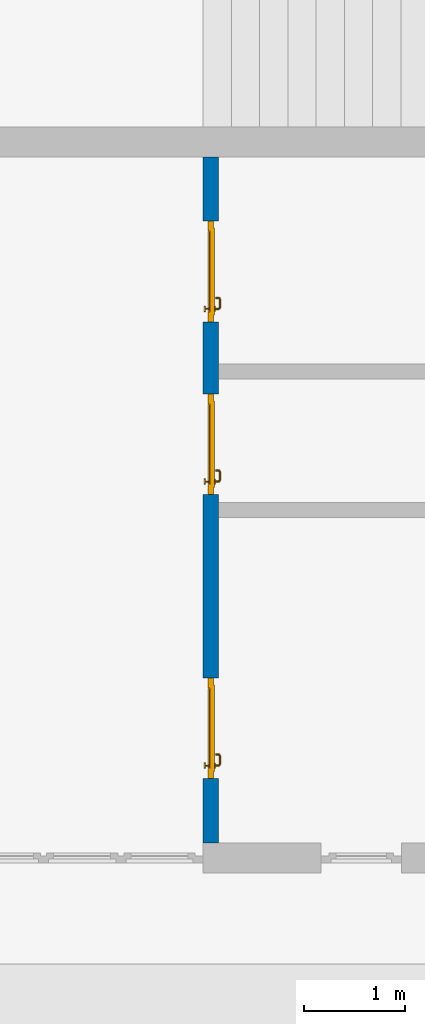
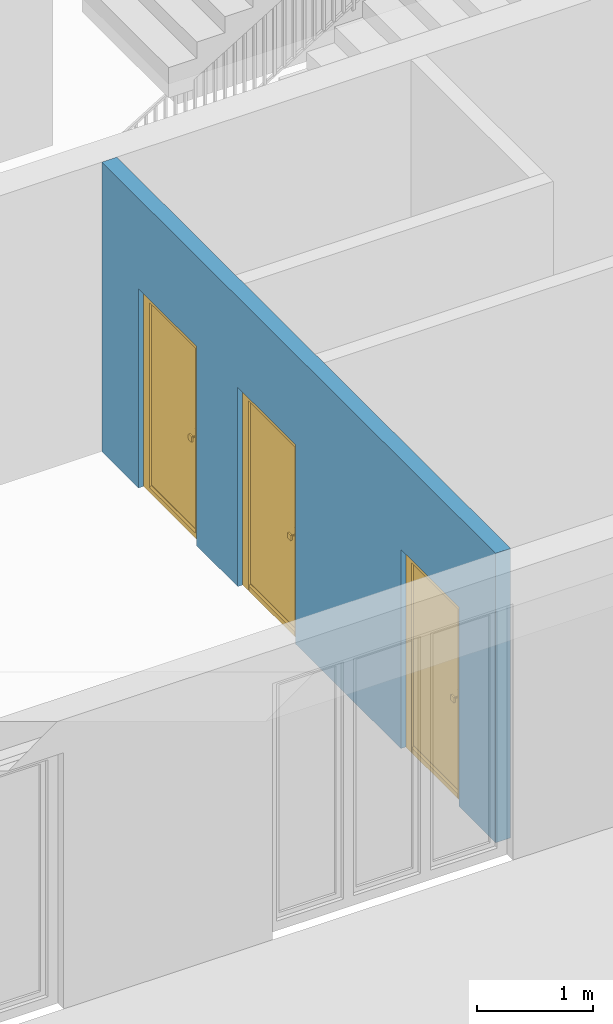
# One storey, part 4 of 23: 3 doors, 1 wall, 3 openings.
"""IFC4 building model written with IfcOpenShell, lengths in metres."""

from ifc_helpers import new_model, entity, si_unit, converted_unit, derived_unit, direction, frame, origin_with_axes, place, context, subcontext, project, spatial, polygons, source, transform, mapped, material, type_object, element, fill, save


model = new_model("IFC4")

# Units and contexts
model_context = context("Model", 3, precision=1e-05, world=origin_with_axes(), true_north=direction((0.0, 1.0)))
body_context = subcontext(model_context, "Body", "Model", "MODEL_VIEW")
ifc_project = project(units=[si_unit("LENGTHUNIT", "METRE"), si_unit("AREAUNIT", "SQUARE_METRE"), si_unit("VOLUMEUNIT", "CUBIC_METRE"), converted_unit("PLANEANGLEUNIT", "DEGREE", entity("IfcPlaneAngleMeasure", 0.0174532925199), si_unit("PLANEANGLEUNIT", "RADIAN"), dimensions=[0, 0, 0, 0, 0, 0, 0]), converted_unit("TIMEUNIT", "Year", entity("IfcTimeMeasure", 31556926.0), si_unit("TIMEUNIT", "SECOND"), dimensions=[0, 0, 1, 0, 0, 0, 0]), si_unit("MASSUNIT", "GRAM", prefix="KILO"), si_unit("THERMODYNAMICTEMPERATUREUNIT", "DEGREE_CELSIUS"), si_unit("LUMINOUSINTENSITYUNIT", "LUMEN"), si_unit("ENERGYUNIT", "JOULE", prefix="MEGA"), derived_unit("THERMALCONDUCTANCEUNIT", [(si_unit("POWERUNIT", "WATT"), 1), (si_unit("LENGTHUNIT", "METRE"), -1), (si_unit("THERMODYNAMICTEMPERATUREUNIT", "KELVIN"), -1)]), derived_unit("SPECIFICHEATCAPACITYUNIT", [(si_unit("ENERGYUNIT", "JOULE"), 1), (si_unit("MASSUNIT", "GRAM", prefix="KILO"), -1), (si_unit("THERMODYNAMICTEMPERATUREUNIT", "KELVIN"), -1)]), derived_unit("MASSDENSITYUNIT", [(si_unit("MASSUNIT", "GRAM", prefix="KILO"), 1), (si_unit("VOLUMEUNIT", "CUBIC_METRE"), -1)])], contexts=[model_context])

# Site, building, storey
site_placement = place(None, origin_with_axes())
site = spatial("IfcSite", under=ifc_project, at=site_placement, CompositionType="ELEMENT")
building_placement = place(site_placement, origin_with_axes())
building = spatial("IfcBuilding", under=site, at=building_placement, CompositionType="ELEMENT")
storey_placement = place(building_placement, origin_with_axes())
storey = spatial("IfcBuildingStorey", under=building, at=storey_placement, Name="0. Geschoss", CompositionType="ELEMENT", Elevation=0.0)

# Wall, openings, doors
ifc_material = material()
wall_type = type_object("IfcWallType", Name="150", PredefinedType="NOTDEFINED")
wall_placement = place(storey_placement, frame((-4.2821993804, -9.92881223104, 0.0), z_axis=(0.0, 0.0, 1.0), x_axis=(0.0, 1.0, 0.0)))
wall = element("IfcWall", 1, at=wall_placement, inside=storey, type_object=wall_type, material=ifc_material, Name="Wand-002", PredefinedType="NOTDEFINED", context=body_context, shape_type="Tessellation", body=[
    polygons([(0.936333441648, -0.15, 0.0), (0.936333441648, -0.15, 2.1), (1.93633344165, -0.15, 2.1), (1.93633344165, -0.15, 0.0), (3.75305810182, -0.15, 0.0), (3.75305810182, -0.15, 2.1), (4.75305810182, -0.15, 2.1), (4.75305810182, -0.15, 0.0), (5.46546310046, -0.15, 0.0), (5.46546310046, -0.15, 2.1), (6.46546310046, -0.15, 2.1), (6.46546310046, -0.15, 0.0), (7.1, -0.15, 0.0), (7.1, -0.15, 3.05), (0.3, -0.15, 3.05), (0.3, -0.15, 0.0), (0.936333441648, -0.05, 0.0), (0.936333441648, 0.0, 0.0), (0.936333441648, 0.0, 2.1), (1.93633344165, 0.0, 2.1), (1.93633344165, -0.05, 0.0), (1.93633344165, 0.0, 0.0), (3.75305810182, 0.0, 0.0), (3.75305810182, 0.0, 2.1), (4.75305810182, 0.0, 2.1), (4.75305810182, 0.0, 0.0), (5.46546310046, 0.0, 0.0), (5.46546310046, 0.0, 2.1), (6.46546310046, 0.0, 2.1), (6.46546310046, 0.0, 0.0), (7.1, 0.0, 0.0), (7.1, 0.0, 3.05), (0.3, 0.0, 3.05), (0.3, 0.0, 0.0)], [[[1, 2, 3, 4, 5, 6, 7, 8, 9, 10, 11, 12, 13, 14, 15, 16]], [[2, 1, 17, 18, 19]], [[3, 2, 19, 20]], [[21, 4, 3, 20, 22]], [[4, 21, 22, 23, 5]], [[23, 24, 6, 5]], [[24, 25, 7, 6]], [[25, 26, 8, 7]], [[27, 9, 8, 26]], [[10, 9, 27, 28]], [[11, 10, 28, 29]], [[12, 11, 29, 30]], [[12, 30, 31, 13]], [[14, 13, 31, 32]], [[14, 32, 33, 15]], [[33, 34, 16, 15]], [[17, 1, 16, 34, 18]], [[23, 22, 20, 19, 18, 34, 33, 32, 31, 30, 29, 28, 27, 26, 25, 24]]], closed=True),
])
opening_1_placement = place(wall_placement, frame((5.96546310046, 0.0, 0.0), z_axis=(0.0, 0.0, 1.0), x_axis=(1.0, 0.0, 0.0)))
opening_1 = element("IfcOpeningElement", 2, at=opening_1_placement, cuts=wall, context=body_context, identifier="Reference", shape_type="Tessellation", body=[
    polygons([(-0.5, -0.05, 0.0), (-0.5, -0.05, 2.1), (-0.5, 0.001, 2.1), (-0.5, 0.001, 0.0), (-0.5, -0.151, 0.0), (-0.5, -0.151, 2.1), (0.5, -0.05, 2.1), (0.5, 0.001, 2.1), (0.5, -0.151, 2.1), (0.5, 0.001, 0.0), (0.5, -0.05, 0.0), (0.5, -0.151, 0.0)], [[[1, 2, 3, 4]], [[2, 1, 5, 6]], [[7, 8, 3, 2, 6, 9]], [[8, 10, 4, 3]], [[1, 4, 10, 11, 12, 5]], [[6, 5, 12, 9]], [[7, 11, 10, 8]], [[11, 7, 9, 12]]], closed=True),
])
opening_2_placement = place(wall_placement, frame((4.25305810182, 0.0, 0.0), z_axis=(0.0, 0.0, 1.0), x_axis=(1.0, 0.0, 0.0)))
opening_2 = element("IfcOpeningElement", 3, at=opening_2_placement, cuts=wall, context=body_context, identifier="Reference", shape_type="Tessellation", body=[
    polygons([(-0.5, -0.05, 0.0), (-0.5, -0.05, 2.1), (-0.5, 0.00100000000001, 2.1), (-0.5, 0.00100000000001, 0.0), (-0.5, -0.151, 0.0), (-0.5, -0.151, 2.1), (0.5, -0.05, 2.1), (0.5, 0.00100000000001, 2.1), (0.5, -0.151, 2.1), (0.5, 0.00100000000001, 0.0), (0.5, -0.05, 0.0), (0.5, -0.151, 0.0)], [[[1, 2, 3, 4]], [[2, 1, 5, 6]], [[7, 8, 3, 2, 6, 9]], [[8, 10, 4, 3]], [[1, 4, 10, 11, 12, 5]], [[6, 5, 12, 9]], [[7, 11, 10, 8]], [[11, 7, 9, 12]]], closed=True),
])
opening_3_placement = place(wall_placement, frame((1.43633344165, 0.0, 0.0), z_axis=(0.0, 0.0, 1.0), x_axis=(1.0, 0.0, 0.0)))
opening_3 = element("IfcOpeningElement", 4, at=opening_3_placement, cuts=wall, context=body_context, identifier="Reference", shape_type="Tessellation", body=[
    polygons([(-0.5, -0.05, 0.0), (-0.5, -0.05, 2.1), (-0.5, 0.00100000000001, 2.1), (-0.5, 0.00100000000001, 0.0), (-0.5, -0.151, 0.0), (-0.5, -0.151, 2.1), (0.5, -0.05, 2.1), (0.5, 0.00100000000001, 2.1), (0.5, -0.151, 2.1), (0.5, 0.00100000000001, 0.0), (0.5, -0.05, 0.0), (0.5, -0.151, 0.0)], [[[1, 2, 3, 4]], [[2, 1, 5, 6]], [[7, 8, 3, 2, 6, 9]], [[8, 10, 4, 3]], [[1, 4, 10, 11, 12, 5]], [[6, 5, 12, 9]], [[7, 11, 10, 8]], [[11, 7, 9, 12]]], closed=True),
])
door_type = type_object("IfcDoorType", Name="Eingang 01 1-Fl 26", OperationType="SINGLE_SWING_LEFT", PredefinedType="DOOR")
shared_shape = source(origin_with_axes(), body_context, "Body", "Tessellation", [
    polygons([(-0.5, -0.05, 0.0), (-0.5, -0.05, 2.1), (-0.5, -0.03, 2.1), (-0.5, -0.03, 0.0), (-0.4, -0.05, 0.0), (-0.4, -0.05, 2.0), (-0.1301, -0.05, 2.0), (-0.0001, -0.05, 2.0), (0.4, -0.05, 2.0), (0.4, -0.05, 0.0), (0.5, -0.05, 0.0), (0.5, -0.05, 2.1), (0.5, -0.03, 2.1), (0.5, -0.03, 0.0), (0.4, -0.03, 0.0), (0.4, -0.03, 2.0), (-0.0001, -0.03, 2.0), (-0.1301, -0.03, 2.0), (-0.4, -0.03, 2.0), (-0.4, -0.03, 0.0)], [[[1, 2, 3, 4]], [[1, 5, 6, 7, 8, 9, 10, 11, 12, 2]], [[2, 12, 13, 3]], [[4, 3, 13, 14, 15, 16, 17, 18, 19, 20]], [[5, 1, 4, 20]], [[6, 5, 20, 19]], [[7, 6, 19, 18]], [[8, 7, 18, 17]], [[9, 8, 17, 16]], [[10, 9, 16, 15]], [[11, 10, 15, 14]], [[12, 11, 14, 13]]], closed=True),
    polygons([(-0.5, -0.03, 0.0), (-0.5, -0.03, 2.1), (-0.5, 0.0, 2.1), (-0.5, 0.0, 0.0), (-0.43, -0.03, 0.0), (-0.43, -0.03, 2.03), (-0.1001, -0.03, 2.03), (-0.0301, -0.03, 2.03), (0.43, -0.03, 2.03), (0.43, -0.03, 0.0), (0.5, -0.03, 0.0), (0.5, -0.03, 2.1), (0.5, 0.0, 2.1), (0.5, 0.0, 0.0), (0.43, 0.0, 0.0), (0.43, 0.0, 2.03), (-0.0301, 0.0, 2.03), (-0.1001, 0.0, 2.03), (-0.43, 0.0, 2.03), (-0.43, 0.0, 0.0)], [[[1, 2, 3, 4]], [[1, 5, 6, 7, 8, 9, 10, 11, 12, 2]], [[2, 12, 13, 3]], [[4, 3, 13, 14, 15, 16, 17, 18, 19, 20]], [[5, 1, 4, 20]], [[6, 5, 20, 19]], [[7, 6, 19, 18]], [[8, 7, 18, 17]], [[9, 8, 17, 16]], [[10, 9, 16, 15]], [[11, 10, 15, 14]], [[12, 11, 14, 13]]], closed=True),
    polygons([(-0.43, 0.01, 0.0), (-0.43, 0.01, 2.03), (0.43, 0.01, 2.03), (0.43, 0.01, 0.0), (-0.43, -0.03, 0.0), (-0.43, -0.03, 2.03), (0.43, -0.03, 2.03), (0.43, -0.03, 0.0)], [[[1, 2, 3, 4]], [[1, 5, 6, 2]], [[2, 6, 7, 3]], [[3, 7, 8, 4]], [[4, 8, 5, 1]], [[8, 7, 6, 5]]], closed=True),
    polygons([(-0.395, -0.05, 0.0), (0.395, -0.05, 0.0), (0.395, -0.05, 0.05), (-0.395, -0.05, 0.05), (-0.395, -0.03, 0.0), (0.395, -0.03, 0.0), (0.395, -0.03, 0.07), (0.395, -0.035, 0.07), (-0.395, -0.035, 0.07), (-0.395, -0.03, 0.07)], [[[1, 2, 3, 4]], [[5, 6, 2, 1]], [[2, 6, 7, 8, 3]], [[4, 3, 8, 9]], [[1, 4, 9, 10, 5]], [[10, 7, 6, 5]], [[9, 8, 7, 10]]], closed=True),
    polygons([(0.3835, 0.02, 1.0733826859), (0.37, 0.02, 1.077), (0.37, 0.0199, 1.077), (0.3835, 0.0199, 1.0733826859), (0.393382685902, 0.02, 1.0635), (0.397, 0.02, 1.05), (0.393382685902, 0.02, 1.0365), (0.3835, 0.02, 1.0266173141), (0.37, 0.02, 1.023), (0.3565, 0.02, 1.0266173141), (0.346617314098, 0.02, 1.0365), (0.343, 0.02, 1.05), (0.346617314098, 0.02, 1.0635), (0.3565, 0.02, 1.0733826859), (0.3565, 0.0199, 1.0733826859), (0.37, 0.0101, 1.077), (0.3835, 0.0101, 1.0733826859), (0.393382685902, 0.0199, 1.0635), (0.397, 0.0199, 1.05), (0.393382685902, 0.0199, 1.0365), (0.3835, 0.0199, 1.0266173141), (0.37, 0.0199, 1.023), (0.3565, 0.0199, 1.0266173141), (0.346617314098, 0.0199, 1.0365), (0.343, 0.0199, 1.05), (0.346617314098, 0.0199, 1.0635), (0.3565, 0.0101, 1.0733826859), (0.37, 0.01, 1.077), (0.3835, 0.01, 1.0733826859), (0.393382685902, 0.0101, 1.0635), (0.397, 0.0101, 1.05), (0.393382685902, 0.0101, 1.0365), (0.3835, 0.0101, 1.0266173141), (0.37, 0.0101, 1.023), (0.3565, 0.0101, 1.0266173141), (0.346617314098, 0.0101, 1.0365), (0.343, 0.0101, 1.05), (0.346617314098, 0.0101, 1.0635), (0.3565, 0.01, 1.0733826859), (0.346617314098, 0.01, 1.0635), (0.343, 0.01, 1.05), (0.346617314098, 0.01, 1.0365), (0.3565, 0.01, 1.0266173141), (0.37, 0.01, 1.023), (0.3835, 0.01, 1.0266173141), (0.393382685902, 0.01, 1.0365), (0.397, 0.01, 1.05), (0.393382685902, 0.01, 1.0635)], [[[1, 2, 3, 4]], [[2, 1, 5, 6, 7, 8, 9, 10, 11, 12, 13, 14]], [[2, 14, 15, 3]], [[4, 3, 16, 17]], [[5, 1, 4, 18]], [[6, 5, 18, 19]], [[7, 6, 19, 20]], [[8, 7, 20, 21]], [[9, 8, 21, 22]], [[10, 9, 22, 23]], [[11, 10, 23, 24]], [[12, 11, 24, 25]], [[13, 12, 25, 26]], [[14, 13, 26, 15]], [[3, 15, 27, 16]], [[17, 16, 28, 29]], [[18, 4, 17, 30]], [[19, 18, 30, 31]], [[20, 19, 31, 32]], [[21, 20, 32, 33]], [[22, 21, 33, 34]], [[23, 22, 34, 35]], [[24, 23, 35, 36]], [[25, 24, 36, 37]], [[26, 25, 37, 38]], [[15, 26, 38, 27]], [[16, 27, 39, 28]], [[28, 39, 40, 41, 42, 43, 44, 45, 46, 47, 48, 29]], [[30, 17, 29, 48]], [[31, 30, 48, 47]], [[32, 31, 47, 46]], [[33, 32, 46, 45]], [[34, 33, 45, 44]], [[35, 34, 44, 43]], [[36, 35, 43, 42]], [[37, 36, 42, 41]], [[38, 37, 41, 40]], [[27, 38, 40, 39]]], closed=True),
    polygons([(0.362532169224, 0.019, 0.959692280177), (0.363279754556, 0.019, 0.961639806549), (0.35705, 0.019, 0.972430057958), (0.347569942042, 0.019, 0.96295), (0.365, 0.019, 0.952886751346), (0.365, 0.019, 0.9544), (0.362532169224, 0.02, 0.959692280177), (0.363279754556, 0.02, 0.961639806549), (0.364624817685, 0.02, 0.965143815798), (0.364624817685, 0.019, 0.965143815798), (0.37, 0.019, 0.967425445323), (0.37, 0.019, 0.9759), (0.357, 0.019, 0.972516660498), (0.347483339502, 0.019, 0.963), (0.365, 0.019, 0.95), (0.3441, 0.019, 0.95), (0.365, 0.019, 0.947113248654), (0.365, 0.019, 0.941339745962), (0.365, 0.019, 0.9375), (0.365, 0.02, 0.9375), (0.365, 0.02, 0.941339745962), (0.365, 0.02, 0.947113248654), (0.365, 0.02, 0.95), (0.365, 0.02, 0.952886751346), (0.365, 0.02, 0.9544), (0.346703916638, 0.02, 0.96345), (0.35655, 0.02, 0.973296083362), (0.37, 0.02, 0.9769), (0.37, 0.02, 0.967425445323), (0.375375182315, 0.019, 0.965143815798), (0.376720245444, 0.019, 0.961639806549), (0.38295, 0.019, 0.972430057958), (0.37, 0.019, 0.976), (0.357, 0.0189, 0.972516660498), (0.347483339502, 0.0189, 0.963), (0.344, 0.019, 0.95), (0.347569942042, 0.019, 0.93705), (0.35705, 0.019, 0.927569942042), (0.37, 0.019, 0.9241), (0.37, 0.019, 0.9325), (0.366464466094, 0.019, 0.933964466094), (0.366464466094, 0.02, 0.933964466094), (0.37, 0.02, 0.9231), (0.35655, 0.02, 0.926703916638), (0.37, 0.02, 0.9325), (0.346703916638, 0.02, 0.93655), (0.3431, 0.02, 0.95), (0.346617314098, 0.02, 0.9635), (0.3565, 0.02, 0.973382685902), (0.37, 0.02, 0.977), (0.375375182315, 0.02, 0.965143815798), (0.38345, 0.02, 0.973296083362), (0.376720245444, 0.02, 0.961639806549), (0.377467830776, 0.02, 0.959692280177), (0.377467830776, 0.019, 0.959692280177), (0.375, 0.019, 0.9544), (0.375, 0.019, 0.952886751346), (0.392430057958, 0.019, 0.96295), (0.383, 0.019, 0.972516660498), (0.37, 0.0189, 0.976), (0.357, 0.0101, 0.972516660498), (0.347483339502, 0.0101, 0.963), (0.344, 0.0189, 0.95), (0.347483339502, 0.019, 0.937), (0.357, 0.019, 0.927483339502), (0.37, 0.019, 0.924), (0.38295, 0.019, 0.927569942042), (0.375, 0.019, 0.941339745962), (0.375, 0.019, 0.9375), (0.373535533906, 0.019, 0.933964466094), (0.37, 0.02, 0.923), (0.3565, 0.02, 0.926617314098), (0.38345, 0.02, 0.926703916638), (0.373535533906, 0.02, 0.933964466094), (0.375, 0.02, 0.9375), (0.375, 0.02, 0.941339745962), (0.346617314098, 0.02, 0.9365), (0.343, 0.02, 0.95), (0.346617314098, 0.0199, 0.9635), (0.3565, 0.0199, 0.973382685902), (0.37, 0.0199, 0.977), (0.3835, 0.02, 0.973382685902), (0.393296083362, 0.02, 0.96345), (0.375, 0.02, 0.952886751346), (0.375, 0.02, 0.9544), (0.375, 0.02, 0.95), (0.375, 0.02, 0.947113248654), (0.375, 0.019, 0.947113248654), (0.375, 0.019, 0.95), (0.3959, 0.019, 0.95), (0.392516660498, 0.019, 0.963), (0.383, 0.0189, 0.972516660498), (0.37, 0.0101, 0.976), (0.357, 0.01, 0.972516660498), (0.347483339502, 0.01, 0.963), (0.344, 0.0101, 0.95), (0.347483339502, 0.0189, 0.937), (0.357, 0.0189, 0.927483339502), (0.37, 0.0189, 0.924), (0.383, 0.019, 0.927483339502), (0.392430057958, 0.019, 0.93705), (0.37, 0.0199, 0.923), (0.3565, 0.0199, 0.926617314098), (0.3835, 0.02, 0.926617314098), (0.393296083362, 0.02, 0.93655), (0.346617314098, 0.0199, 0.9365), (0.343, 0.0199, 0.95), (0.346617314098, 0.0101, 0.9635), (0.3565, 0.0101, 0.973382685902), (0.37, 0.0101, 0.977), (0.3835, 0.0199, 0.973382685902), (0.393382685902, 0.02, 0.9635), (0.3969, 0.02, 0.95), (0.396, 0.019, 0.95), (0.392516660498, 0.0189, 0.963), (0.383, 0.0101, 0.972516660498), (0.37, 0.01, 0.976), (0.35695, 0.01, 0.972603263039), (0.347396736961, 0.01, 0.96305), (0.344, 0.01, 0.95), (0.347483339502, 0.0101, 0.937), (0.357, 0.0101, 0.927483339502), (0.37, 0.0101, 0.924), (0.383, 0.0189, 0.927483339502), (0.392516660498, 0.019, 0.937), (0.37, 0.0101, 0.923), (0.3565, 0.0101, 0.926617314098), (0.3835, 0.0199, 0.926617314098), (0.393382685902, 0.02, 0.9365), (0.346617314098, 0.0101, 0.9365), (0.343, 0.0101, 0.95), (0.346617314098, 0.01, 0.9635), (0.3565, 0.01, 0.973382685902), (0.37, 0.01, 0.977), (0.3835, 0.0101, 0.973382685902), (0.393382685902, 0.0199, 0.9635), (0.397, 0.02, 0.95), (0.396, 0.0189, 0.95), (0.392516660498, 0.0101, 0.963), (0.383, 0.01, 0.972516660498), (0.37, 0.01, 0.9761), (0.35655, 0.01, 0.973296083362), (0.346703916638, 0.01, 0.96345), (0.3439, 0.01, 0.95), (0.347483339502, 0.01, 0.937), (0.357, 0.01, 0.927483339502), (0.37, 0.01, 0.924), (0.383, 0.0101, 0.927483339502), (0.392516660498, 0.0189, 0.937), (0.37, 0.01, 0.923), (0.3565, 0.01, 0.926617314098), (0.3835, 0.0101, 0.926617314098), (0.393382685902, 0.0199, 0.9365), (0.346617314098, 0.01, 0.9365), (0.343, 0.01, 0.95), (0.37, 0.01, 0.9769), (0.3835, 0.01, 0.973382685902), (0.393382685902, 0.0101, 0.9635), (0.397, 0.0199, 0.95), (0.396, 0.0101, 0.95), (0.392516660498, 0.01, 0.963), (0.38305, 0.01, 0.972603263039), (0.3431, 0.01, 0.95), (0.347396736961, 0.01, 0.93695), (0.35695, 0.01, 0.927396736961), (0.37, 0.01, 0.9239), (0.383, 0.01, 0.927483339502), (0.392516660498, 0.0101, 0.937), (0.37, 0.01, 0.9231), (0.35655, 0.01, 0.926703916638), (0.3835, 0.01, 0.926617314098), (0.393382685902, 0.0101, 0.9365), (0.346703916638, 0.01, 0.93655), (0.38345, 0.01, 0.973296083362), (0.393382685902, 0.01, 0.9635), (0.397, 0.0101, 0.95), (0.396, 0.01, 0.95), (0.392603263039, 0.01, 0.96305), (0.38305, 0.01, 0.927396736961), (0.392516660498, 0.01, 0.937), (0.38345, 0.01, 0.926703916638), (0.393382685902, 0.01, 0.9365), (0.393296083362, 0.01, 0.96345), (0.397, 0.01, 0.95), (0.3961, 0.01, 0.95), (0.392603263039, 0.01, 0.93695), (0.393296083362, 0.01, 0.93655), (0.3969, 0.01, 0.95)], [[[1, 2, 3, 4, 5, 6]], [[1, 7, 8, 9, 10, 2]], [[10, 11, 12, 3, 2]], [[4, 3, 13, 14]], [[15, 5, 4, 16]], [[6, 5, 15, 17, 18, 19, 20, 21, 22, 23, 24, 25]], [[6, 25, 7, 1]], [[7, 25, 24, 26, 27, 8]], [[9, 8, 27, 28, 29]], [[10, 9, 29, 11]], [[30, 31, 32, 12, 11]], [[3, 12, 33, 13]], [[14, 13, 34, 35]], [[16, 4, 14, 36]], [[17, 15, 16, 37]], [[18, 17, 37, 38]], [[38, 39, 40, 41, 19, 18]], [[19, 41, 42, 20]], [[43, 44, 21, 20, 42, 45]], [[22, 21, 44, 46]], [[23, 22, 46, 47]], [[24, 23, 47, 26]], [[48, 49, 27, 26]], [[49, 50, 28, 27]], [[51, 29, 28, 52, 53]], [[11, 29, 51, 30]], [[30, 51, 53, 54, 55, 31]], [[55, 56, 57, 58, 32, 31]], [[12, 32, 59, 33]], [[13, 33, 60, 34]], [[35, 34, 61, 62]], [[36, 14, 35, 63]], [[37, 16, 36, 64]], [[38, 37, 64, 65]], [[39, 38, 65, 66]], [[39, 67, 68, 69, 70, 40]], [[41, 40, 45, 42]], [[71, 72, 44, 43]], [[73, 43, 45, 74, 75, 76]], [[72, 77, 46, 44]], [[77, 78, 47, 46]], [[78, 48, 26, 47]], [[79, 80, 49, 48]], [[80, 81, 50, 49]], [[50, 82, 52, 28]], [[54, 53, 52, 83, 84, 85]], [[55, 54, 85, 56]], [[85, 84, 86, 87, 76, 75, 69, 68, 88, 89, 57, 56]], [[57, 89, 90, 58]], [[32, 58, 91, 59]], [[33, 59, 92, 60]], [[34, 60, 93, 61]], [[62, 61, 94, 95]], [[63, 35, 62, 96]], [[64, 36, 63, 97]], [[65, 64, 97, 98]], [[66, 65, 98, 99]], [[67, 39, 66, 100]], [[88, 68, 67, 101]], [[70, 69, 75, 74]], [[40, 70, 74, 45]], [[102, 103, 72, 71]], [[104, 71, 43, 73]], [[76, 87, 105, 73]], [[103, 106, 77, 72]], [[106, 107, 78, 77]], [[107, 79, 48, 78]], [[108, 109, 80, 79]], [[109, 110, 81, 80]], [[81, 111, 82, 50]], [[82, 112, 83, 52]], [[86, 84, 83, 113]], [[87, 86, 113, 105]], [[89, 88, 101, 90]], [[58, 90, 114, 91]], [[59, 91, 115, 92]], [[60, 92, 116, 93]], [[61, 93, 117, 94]], [[95, 94, 118, 119]], [[96, 62, 95, 120]], [[97, 63, 96, 121]], [[98, 97, 121, 122]], [[99, 98, 122, 123]], [[100, 66, 99, 124]], [[101, 67, 100, 125]], [[126, 127, 103, 102]], [[128, 102, 71, 104]], [[129, 104, 73, 105]], [[127, 130, 106, 103]], [[130, 131, 107, 106]], [[131, 108, 79, 107]], [[132, 133, 109, 108]], [[133, 134, 110, 109]], [[110, 135, 111, 81]], [[111, 136, 112, 82]], [[112, 137, 113, 83]], [[137, 129, 105, 113]], [[90, 101, 125, 114]], [[91, 114, 138, 115]], [[92, 115, 139, 116]], [[93, 116, 140, 117]], [[94, 117, 141, 118]], [[119, 118, 142, 143]], [[120, 95, 119, 144]], [[121, 96, 120, 145]], [[122, 121, 145, 146]], [[123, 122, 146, 147]], [[124, 99, 123, 148]], [[125, 100, 124, 149]], [[150, 151, 127, 126]], [[152, 126, 102, 128]], [[153, 128, 104, 129]], [[151, 154, 130, 127]], [[154, 155, 131, 130]], [[155, 132, 108, 131]], [[143, 142, 133, 132]], [[142, 156, 134, 133]], [[134, 157, 135, 110]], [[135, 158, 136, 111]], [[136, 159, 137, 112]], [[159, 153, 129, 137]], [[114, 125, 149, 138]], [[115, 138, 160, 139]], [[116, 139, 161, 140]], [[117, 140, 162, 141]], [[118, 141, 156, 142]], [[144, 119, 143, 163]], [[145, 120, 144, 164]], [[146, 145, 164, 165]], [[147, 146, 165, 166]], [[148, 123, 147, 167]], [[149, 124, 148, 168]], [[169, 170, 151, 150]], [[171, 150, 126, 152]], [[172, 152, 128, 153]], [[170, 173, 154, 151]], [[173, 163, 155, 154]], [[163, 143, 132, 155]], [[156, 174, 157, 134]], [[157, 175, 158, 135]], [[158, 176, 159, 136]], [[176, 172, 153, 159]], [[138, 149, 168, 160]], [[139, 160, 177, 161]], [[140, 161, 178, 162]], [[141, 162, 174, 156]], [[164, 144, 163, 173]], [[165, 164, 173, 170]], [[166, 165, 170, 169]], [[167, 147, 166, 179]], [[168, 148, 167, 180]], [[181, 169, 150, 171]], [[182, 171, 152, 172]], [[174, 183, 175, 157]], [[175, 184, 176, 158]], [[184, 182, 172, 176]], [[160, 168, 180, 177]], [[161, 177, 185, 178]], [[162, 178, 183, 174]], [[179, 166, 169, 181]], [[180, 167, 179, 186]], [[187, 181, 171, 182]], [[183, 188, 184, 175]], [[188, 187, 182, 184]], [[177, 180, 186, 185]], [[178, 185, 188, 183]], [[186, 179, 181, 187]], [[185, 186, 187, 188]]], closed=True),
    polygons([(0.38, 0.02, 1.05), (0.377071067812, 0.02, 1.04292893219), (0.377071067812, 0.050696439392, 1.04292893219), (0.38, 0.0509849140336, 1.05), (0.37, 0.02, 1.04), (0.37, 0.05, 1.04), (0.375518993221, 0.0584992452783, 1.04292893219), (0.378277987014, 0.0596420579258, 1.05), (0.377071067812, 0.02, 1.05707106781), (0.377071067812, 0.050696439392, 1.05707106781), (0.362928932188, 0.02, 1.04292893219), (0.362928932188, 0.049303560608, 1.04292893219), (0.368858192988, 0.0557402514855, 1.04), (0.370704557509, 0.0657045575088, 1.04292893219), (0.372816199938, 0.0678161999379, 1.05), (0.375518993221, 0.0584992452783, 1.05707106781), (0.37, 0.02, 1.06), (0.37, 0.05, 1.06), (0.36, 0.02, 1.05), (0.36, 0.0490150859664, 1.05), (0.362197392755, 0.0529812576926, 1.04292893219), (0.365606601718, 0.0606066017178, 1.04), (0.363499245278, 0.0705189932208, 1.04292893219), (0.364642057926, 0.0732779870137, 1.05), (0.370704557509, 0.0657045575088, 1.05707106781), (0.368858192988, 0.0557402514855, 1.06), (0.362928932188, 0.02, 1.05707106781), (0.362928932188, 0.049303560608, 1.05707106781), (0.359438398962, 0.0518384450452, 1.05), (0.360508645927, 0.0555086459268, 1.04292893219), (0.360740251485, 0.0638581929877, 1.04), (0.355696439392, 0.0720710678119, 1.04292893219), (0.355984914034, 0.075, 1.05), (0.363499245278, 0.0705189932208, 1.05707106781), (0.365606601718, 0.0606066017178, 1.06), (0.362197392755, 0.0529812576926, 1.05707106781), (0.358397003498, 0.0533970034977, 1.05), (0.357981257693, 0.0571973927545, 1.04292893219), (0.355, 0.065, 1.04), (0.274303560608, 0.0720710678119, 1.04292893219), (0.274015085966, 0.075, 1.05), (0.355696439392, 0.0720710678119, 1.05707106781), (0.360740251485, 0.0638581929877, 1.06), (0.360508645927, 0.0555086459268, 1.05707106781), (0.356838445045, 0.0544383989617, 1.05), (0.354303560608, 0.0579289321881, 1.04292893219), (0.275, 0.065, 1.04), (0.266500754722, 0.0705189932208, 1.04292893219), (0.265357942074, 0.0732779870137, 1.05), (0.274303560608, 0.0720710678119, 1.05707106781), (0.355, 0.065, 1.06), (0.357981257693, 0.0571973927545, 1.05707106781), (0.354015085966, 0.055, 1.05), (0.275696439392, 0.0579289321881, 1.04292893219), (0.269259748515, 0.0638581929877, 1.04), (0.259295442491, 0.0657045575088, 1.04292893219), (0.257183800062, 0.0678161999379, 1.05), (0.266500754722, 0.0705189932208, 1.05707106781), (0.275, 0.065, 1.06), (0.354303560608, 0.0579289321881, 1.05707106781), (0.275984914034, 0.055, 1.05), (0.272018742307, 0.0571973927545, 1.04292893219), (0.264393398282, 0.0606066017178, 1.04), (0.254481006779, 0.0584992452783, 1.04292893219), (0.251722012986, 0.0596420579258, 1.05), (0.259295442491, 0.0657045575088, 1.05707106781), (0.269259748515, 0.0638581929877, 1.06), (0.275696439392, 0.0579289321881, 1.05707106781), (0.273161554955, 0.0544383989617, 1.05), (0.269491354073, 0.0555086459268, 1.04292893219), (0.261141807012, 0.0557402514855, 1.04), (0.252928932188, 0.050696439392, 1.04292893219), (0.25, 0.0509849140336, 1.05), (0.254481006779, 0.0584992452783, 1.05707106781), (0.264393398282, 0.0606066017178, 1.06), (0.272018742307, 0.0571973927545, 1.05707106781), (0.271602996502, 0.0533970034977, 1.05), (0.267802607245, 0.0529812576926, 1.04292893219), (0.26, 0.05, 1.04), (0.252928932188, 0.02, 1.04292893219), (0.25, 0.02, 1.05), (0.252928932188, 0.050696439392, 1.05707106781), (0.261141807012, 0.0557402514855, 1.06), (0.269491354073, 0.0555086459268, 1.05707106781), (0.270561601038, 0.0518384450452, 1.05), (0.267071067812, 0.049303560608, 1.04292893219), (0.26, 0.02, 1.04), (0.267071067812, 0.02, 1.04292893219), (0.27, 0.02, 1.05), (0.267071067812, 0.02, 1.05707106781), (0.26, 0.02, 1.06), (0.252928932188, 0.02, 1.05707106781), (0.26, 0.05, 1.06), (0.267802607245, 0.0529812576926, 1.05707106781), (0.27, 0.0490150859664, 1.05), (0.267071067812, 0.049303560608, 1.05707106781)], [[[1, 2, 3, 4]], [[2, 5, 6, 3]], [[4, 3, 7, 8]], [[9, 1, 4, 10]], [[5, 11, 12, 6]], [[3, 6, 13, 7]], [[8, 7, 14, 15]], [[10, 4, 8, 16]], [[17, 9, 10, 18]], [[11, 19, 20, 12]], [[6, 12, 21, 13]], [[7, 13, 22, 14]], [[15, 14, 23, 24]], [[16, 8, 15, 25]], [[18, 10, 16, 26]], [[27, 17, 18, 28]], [[19, 27, 28, 20]], [[12, 20, 29, 21]], [[13, 21, 30, 22]], [[14, 22, 31, 23]], [[24, 23, 32, 33]], [[25, 15, 24, 34]], [[26, 16, 25, 35]], [[28, 18, 26, 36]], [[20, 28, 36, 29]], [[21, 29, 37, 30]], [[22, 30, 38, 31]], [[23, 31, 39, 32]], [[33, 32, 40, 41]], [[34, 24, 33, 42]], [[35, 25, 34, 43]], [[36, 26, 35, 44]], [[29, 36, 44, 37]], [[30, 37, 45, 38]], [[31, 38, 46, 39]], [[32, 39, 47, 40]], [[41, 40, 48, 49]], [[42, 33, 41, 50]], [[43, 34, 42, 51]], [[44, 35, 43, 52]], [[37, 44, 52, 45]], [[38, 45, 53, 46]], [[39, 46, 54, 47]], [[40, 47, 55, 48]], [[49, 48, 56, 57]], [[50, 41, 49, 58]], [[51, 42, 50, 59]], [[52, 43, 51, 60]], [[45, 52, 60, 53]], [[46, 53, 61, 54]], [[47, 54, 62, 55]], [[48, 55, 63, 56]], [[57, 56, 64, 65]], [[58, 49, 57, 66]], [[59, 50, 58, 67]], [[60, 51, 59, 68]], [[53, 60, 68, 61]], [[54, 61, 69, 62]], [[55, 62, 70, 63]], [[56, 63, 71, 64]], [[65, 64, 72, 73]], [[66, 57, 65, 74]], [[67, 58, 66, 75]], [[68, 59, 67, 76]], [[61, 68, 76, 69]], [[62, 69, 77, 70]], [[63, 70, 78, 71]], [[64, 71, 79, 72]], [[73, 72, 80, 81]], [[74, 65, 73, 82]], [[75, 66, 74, 83]], [[76, 67, 75, 84]], [[69, 76, 84, 77]], [[70, 77, 85, 78]], [[71, 78, 86, 79]], [[72, 79, 87, 80]], [[81, 80, 87, 88, 89, 90, 91, 92]], [[82, 73, 81, 92]], [[83, 74, 82, 93]], [[84, 75, 83, 94]], [[77, 84, 94, 85]], [[78, 85, 95, 86]], [[79, 86, 88, 87]], [[86, 95, 89, 88]], [[95, 96, 90, 89]], [[96, 93, 91, 90]], [[93, 82, 92, 91]], [[94, 83, 93, 96]], [[85, 94, 96, 95]]], closed=False),
    polygons([(0.364696699141, -0.035, 1.04469669914), (0.3625, -0.035, 1.05), (0.364696699141, -0.035, 1.05530330086), (0.37, -0.035, 1.0575), (0.375303300859, -0.035, 1.05530330086), (0.3775, -0.035, 1.05), (0.375303300859, -0.035, 1.04469669914), (0.37, -0.035, 1.0425), (0.364696699141, -0.075, 1.04469669914), (0.3625, -0.075, 1.05), (0.364696699141, -0.075, 1.05530330086), (0.37, -0.075, 1.0575), (0.375303300859, -0.075, 1.05530330086), (0.3775, -0.075, 1.05), (0.375303300859, -0.075, 1.04469669914), (0.37, -0.075, 1.0425)], [[[1, 2, 3, 4, 5, 6, 7, 8]], [[1, 9, 10, 2]], [[2, 10, 11, 3]], [[3, 11, 12, 4]], [[4, 12, 13, 5]], [[5, 13, 14, 6]], [[6, 14, 15, 7]], [[7, 15, 16, 8]], [[8, 16, 9, 1]], [[9, 16, 15, 14, 13, 12, 11, 10]]], closed=True),
    polygons([(0.395, -0.03, 0.975), (0.395, -0.035, 0.975), (0.393096988313, -0.035, 0.965432914191), (0.393096988313, -0.03, 0.965432914191), (0.395, -0.03, 1.1), (0.395, -0.035, 1.1), (0.393096988313, -0.035, 1.10956708581), (0.38767766953, -0.035, 1.11767766953), (0.379567085809, -0.035, 1.12309698831), (0.37, -0.035, 1.125), (0.360432914191, -0.035, 1.12309698831), (0.35232233047, -0.035, 1.11767766953), (0.346903011687, -0.035, 1.10956708581), (0.345, -0.035, 1.1), (0.345, -0.035, 0.975), (0.346903011687, -0.035, 0.965432914191), (0.35232233047, -0.035, 0.95732233047), (0.360432914191, -0.035, 0.951903011687), (0.37, -0.035, 0.95), (0.379567085809, -0.035, 0.951903011687), (0.38767766953, -0.035, 0.95732233047), (0.38767766953, -0.03, 0.95732233047), (0.379567085809, -0.03, 0.951903011687), (0.37, -0.03, 0.95), (0.360432914191, -0.03, 0.951903011687), (0.35232233047, -0.03, 0.95732233047), (0.346903011687, -0.03, 0.965432914191), (0.345, -0.03, 0.975), (0.345, -0.03, 1.1), (0.346903011687, -0.03, 1.10956708581), (0.35232233047, -0.03, 1.11767766953), (0.360432914191, -0.03, 1.12309698831), (0.37, -0.03, 1.125), (0.379567085809, -0.03, 1.12309698831), (0.38767766953, -0.03, 1.11767766953), (0.393096988313, -0.03, 1.10956708581)], [[[1, 2, 3, 4]], [[5, 6, 2, 1]], [[2, 6, 7, 8, 9, 10, 11, 12, 13, 14, 15, 16, 17, 18, 19, 20, 21, 3]], [[4, 3, 21, 22]], [[1, 4, 22, 23, 24, 25, 26, 27, 28, 29, 30, 31, 32, 33, 34, 35, 36, 5]], [[36, 7, 6, 5]], [[35, 8, 7, 36]], [[34, 9, 8, 35]], [[33, 10, 9, 34]], [[32, 11, 10, 33]], [[31, 12, 11, 32]], [[30, 13, 12, 31]], [[29, 14, 13, 30]], [[28, 15, 14, 29]], [[27, 16, 15, 28]], [[26, 17, 16, 27]], [[25, 18, 17, 26]], [[24, 19, 18, 25]], [[23, 20, 19, 24]], [[22, 21, 20, 23]]], closed=True),
    polygons([(0.39, -0.075, 1.08), (0.39, -0.09, 1.08), (0.395, -0.09, 1.07866025404), (0.395, -0.075, 1.07866025404), (0.35, -0.075, 1.08), (0.35, -0.09, 1.08), (0.345, -0.09, 1.07866025404), (0.341339745962, -0.09, 1.075), (0.34, -0.09, 1.07), (0.34, -0.09, 1.03), (0.341339745962, -0.09, 1.025), (0.345, -0.09, 1.02133974596), (0.35, -0.09, 1.02), (0.39, -0.09, 1.02), (0.395, -0.09, 1.02133974596), (0.398660254038, -0.09, 1.025), (0.4, -0.09, 1.03), (0.4, -0.09, 1.07), (0.398660254038, -0.09, 1.075), (0.398660254038, -0.075, 1.075), (0.4, -0.075, 1.07), (0.4, -0.075, 1.03), (0.398660254038, -0.075, 1.025), (0.395, -0.075, 1.02133974596), (0.39, -0.075, 1.02), (0.35, -0.075, 1.02), (0.345, -0.075, 1.02133974596), (0.341339745962, -0.075, 1.025), (0.34, -0.075, 1.03), (0.34, -0.075, 1.07), (0.341339745962, -0.075, 1.075), (0.345, -0.075, 1.07866025404)], [[[1, 2, 3, 4]], [[5, 6, 2, 1]], [[2, 6, 7, 8, 9, 10, 11, 12, 13, 14, 15, 16, 17, 18, 19, 3]], [[4, 3, 19, 20]], [[1, 4, 20, 21, 22, 23, 24, 25, 26, 27, 28, 29, 30, 31, 32, 5]], [[32, 7, 6, 5]], [[31, 8, 7, 32]], [[30, 9, 8, 31]], [[29, 10, 9, 30]], [[28, 11, 10, 29]], [[27, 12, 11, 28]], [[26, 13, 12, 27]], [[25, 14, 13, 26]], [[24, 15, 14, 25]], [[23, 16, 15, 24]], [[22, 17, 16, 23]], [[21, 18, 17, 22]], [[20, 19, 18, 21]]], closed=True),
])
door_1_placement = place(opening_1_placement, frame((0.4, 0.0, 0.0), z_axis=(0.0, 0.0, 1.0), x_axis=(-1.0, 0.0, 0.0)))
door_1 = element("IfcDoor", 5, at=door_1_placement, inside=storey, type_object=door_type, OverallHeight=2.1, OverallWidth=1.0, PredefinedType="DOOR", context=body_context, shape_type="MappedRepresentation", body=[
    mapped(shared_shape, transform((0.4, 0.1, 0.0))),
])
fill(opening_1, door_1)
door_2_placement = place(opening_2_placement, frame((0.4, 0.0, 0.0), z_axis=(0.0, 0.0, 1.0), x_axis=(-1.0, 0.0, 0.0)))
door_2 = element("IfcDoor", 6, at=door_2_placement, inside=storey, type_object=door_type, OverallHeight=2.1, OverallWidth=1.0, PredefinedType="DOOR", context=body_context, shape_type="MappedRepresentation", body=[
    mapped(shared_shape, transform((0.4, 0.1, 0.0))),
])
fill(opening_2, door_2)
door_3_placement = place(opening_3_placement, frame((0.4, 0.0, 0.0), z_axis=(0.0, 0.0, 1.0), x_axis=(-1.0, 0.0, 0.0)))
door_3 = element("IfcDoor", 7, at=door_3_placement, inside=storey, type_object=door_type, OverallHeight=2.1, OverallWidth=1.0, PredefinedType="DOOR", context=body_context, shape_type="MappedRepresentation", body=[
    mapped(shared_shape, transform((0.4, 0.1, 0.0))),
])
fill(opening_3, door_3)

save(model, "model.ifc")
